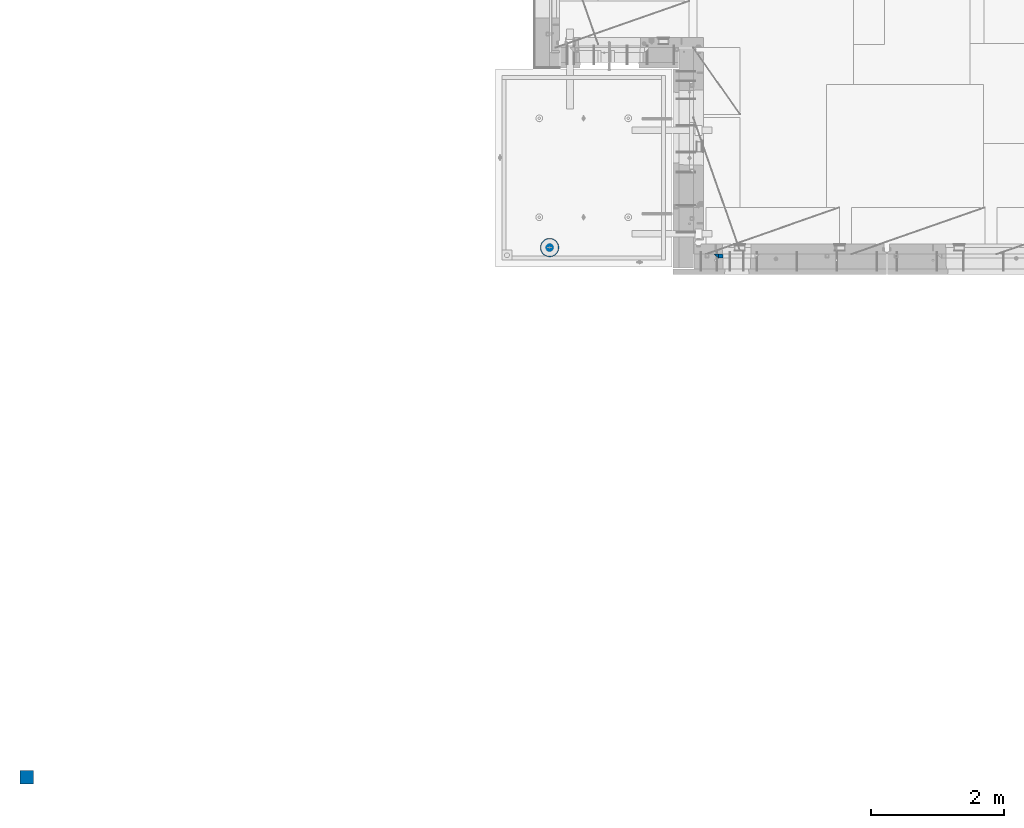
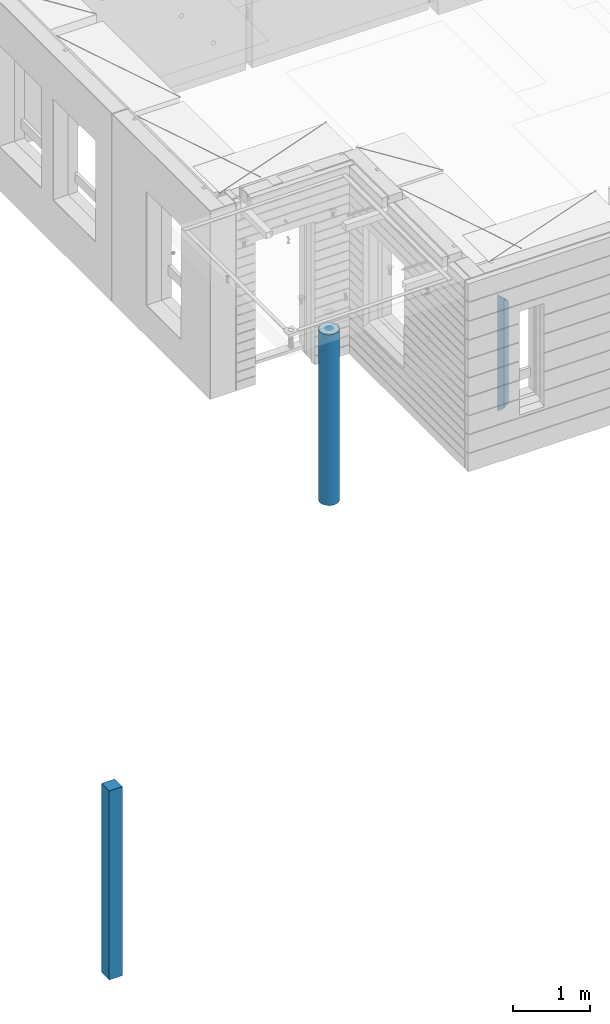
# One storey, part 1 of 352: 4 columns, 3 elements without a shape of their own.
"""IFC2X3 building model written with IfcOpenShell, lengths in millimetres."""

from ifc_helpers import new_model, si_unit, frame, origin_with_axes, place, context, subcontext, project, spatial, faceted_brep, material, type_object, element, aggregate, save


model = new_model("IFC2X3")

# Units and contexts
model_context = context("Model", 3, precision=1e-05, world=origin_with_axes())
body_context = subcontext(model_context, "Body", "Model", "MODEL_VIEW")
ifc_project = project(units=[si_unit("LENGTHUNIT", "METRE", prefix="MILLI"), si_unit("AREAUNIT", "SQUARE_METRE"), si_unit("VOLUMEUNIT", "CUBIC_METRE"), si_unit("MASSUNIT", "GRAM", prefix="KILO"), si_unit("TIMEUNIT", "SECOND"), si_unit("PLANEANGLEUNIT", "RADIAN"), si_unit("SOLIDANGLEUNIT", "STERADIAN"), si_unit("THERMODYNAMICTEMPERATUREUNIT", "DEGREE_CELSIUS"), si_unit("LUMINOUSINTENSITYUNIT", "LUMEN")], contexts=[model_context])

# Site, building, storey
site_placement = place(None, origin_with_axes())
site = spatial("IfcSite", under=ifc_project, at=site_placement, CompositionType="ELEMENT")
building_placement = place(site_placement, origin_with_axes())
building = spatial("IfcBuilding", under=site, at=building_placement, CompositionType="ELEMENT")
storey_placement = place(building_placement, origin_with_axes())
storey = spatial("IfcBuildingStorey", under=building, at=storey_placement, Name="6", CompositionType="ELEMENT", Elevation=0.0)

# Assembly, columns
assembly_1_placement = place(storey_placement, origin_with_axes())
assembly_1 = element("IfcElementAssembly", 1, at=assembly_1_placement, inside=storey, AssemblyPlace="NOTDEFINED", PredefinedType="REINFORCEMENT_UNIT")
ifc_material_1 = material(Name="CONCRETE/C25/30")
column_type_1 = type_object("IfcColumnType", PredefinedType="NOTDEFINED")
column_1_placement = place(assembly_1_placement, frame((10354.997879677, 7820.0, 97320.0), z_axis=(1.0, 0.0, 0.0), x_axis=(0.0, 0.0, 1.0)))
column_1 = element("IfcColumn", 2, at=column_1_placement, type_object=column_type_1, material=ifc_material_1, Name="SK", context=body_context, shape_type="Brep", body=[
    faceted_brep([(1795.00000000001, -30.0, 30.0), (1855.0, -30.0, -30.0), (1795.00000000001, 30.0, 30.0), (60.0000000000073, -30.0, 30.0), (0.0, -30.0, -30.0), (60.0000000000073, 30.0, 30.0)], [[[0, 1, 2]], [[1, 0, 3, 4]], [[2, 1, 4, 5]], [[0, 2, 5, 3]], [[5, 4, 3]]]),
])
column_type_2 = type_object("IfcColumnType", PredefinedType="NOTDEFINED")
column_2_placement = place(assembly_1_placement, frame((10419.997879677, 7820.0, 97380.0), z_axis=(1.0, 0.0, 0.0), x_axis=(0.0, 0.0, 1.0)))
column_2 = element("IfcColumn", 3, at=column_2_placement, type_object=column_type_2, material=ifc_material_1, Name="SK", context=body_context, shape_type="Brep", body=[
    faceted_brep([(1735.0, -30.0, -35.0), (1735.0, 30.0, -35.0), (1678.70525582272, 30.0, 30.6772015545812), (1680.09521721235, -30.0, 29.0555799329595), (56.2947441772849, 30.0, 30.6772015545812), (54.9047827876348, -30.0, 29.0555799329595), (0.0, -30.0, -35.0), (0.0, 30.0, -35.0)], [[[0, 1, 2, 3]], [[3, 2, 4, 5]], [[0, 3, 5, 6]], [[1, 0, 6, 7]], [[2, 1, 7, 4]], [[6, 5, 4, 7]]]),
])
aggregate(assembly_1, [column_1, column_2])

# Assembly, column
assembly_2_placement = place(storey_placement, origin_with_axes())
assembly_2 = element("IfcElementAssembly", 4, at=assembly_2_placement, inside=storey, AssemblyPlace="NOTDEFINED", PredefinedType="REINFORCEMENT_UNIT")
ifc_material_2 = material(Name="CONCRETE/Concrete_Undefined")
column_type_3 = type_object("IfcColumnType", PredefinedType="NOTDEFINED")
column_3_placement = place(assembly_2_placement, frame((0.0, 0.0, 96760.0), z_axis=(0.0, 1.0, 0.0), x_axis=(0.0, 0.0, 1.0)))
column_3 = element("IfcColumn", 5, at=column_3_placement, type_object=column_type_3, material=ifc_material_2, context=body_context, shape_type="Brep", body=[
    faceted_brep([(0.0, 100.0, -100.0), (0.0, 100.0, 100.0), (3000.0, 100.0, 100.0), (3000.0, 100.0, -100.0), (0.0, -100.0, 100.0), (3000.0, -100.0, 100.0), (0.0, -100.0, -100.0), (3000.0, -100.0, -100.0)], [[[0, 1, 2, 3]], [[1, 4, 5, 2]], [[4, 6, 7, 5]], [[6, 0, 3, 7]], [[5, 7, 3, 2]], [[6, 4, 1, 0]]]),
])
aggregate(assembly_2, [column_3])

assembly_3_placement = place(storey_placement, origin_with_axes())
assembly_3 = element("IfcElementAssembly", 6, at=assembly_3_placement, inside=storey, AssemblyPlace="NOTDEFINED", PredefinedType="REINFORCEMENT_UNIT")
ifc_material_3 = material(Name="CONCRETE/C30/37")
column_type_4 = type_object("IfcColumnType", Name="D280", PredefinedType="NOTDEFINED")
column_4_placement = place(assembly_3_placement, frame((7849.99879520436, 7949.98488883804, 96725.0), z_axis=(-1.0, 3.00000001838171e-08, 0.0), x_axis=(0.0, 0.0, 1.0)))
column_4 = element("IfcColumn", 7, at=column_4_placement, type_object=column_type_4, material=ifc_material_3, ObjectType="D280", context=body_context, shape_type="Brep", body=[
    faceted_brep([(0.0, -140.0, 0.0), (0.0, -136.489907705454, -31.1529307538876), (2710.0, -136.489907705454, -31.1529307538876), (2710.0, -140.0, 0.0), (0.0, -126.135641506338, -60.7437234764584), (2710.0, -126.135641506338, -60.7437234764584), (0.0, -109.456407545524, -87.2885722602223), (2710.0, -109.456407545524, -87.2885722602223), (0.0, -87.2885722602223, -109.456407545527), (2710.0, -87.2885722602223, -109.456407545527), (0.0, -60.7437234764584, -126.135641506342), (2710.0, -60.7437234764584, -126.135641506342), (0.0, -31.152930753884, -136.489907705458), (2710.0, -31.152930753884, -136.489907705458), (0.0, 0.0, -140.0), (2710.0, 0.0, -140.0), (0.0, 31.152930753884, -136.489907705458), (2710.0, 31.152930753884, -136.489907705458), (0.0, 60.7437234764584, -126.135641506342), (2710.0, 60.7437234764584, -126.135641506342), (0.0, 87.2885722602223, -109.456407545527), (2710.0, 87.2885722602223, -109.456407545527), (0.0, 109.456407545524, -87.2885722602223), (2710.0, 109.456407545524, -87.2885722602223), (0.0, 126.135641506338, -60.7437234764584), (2710.0, 126.135641506338, -60.7437234764584), (0.0, 136.489907705454, -31.1529307538876), (2710.0, 136.489907705454, -31.1529307538876), (0.0, 140.0, 0.0), (2710.0, 140.0, 0.0), (0.0, 136.489907705454, 31.1529307538876), (2710.0, 136.489907705454, 31.1529307538876), (0.0, 126.135641506338, 60.7437234764584), (2710.0, 126.135641506338, 60.7437234764584), (0.0, 109.456407545524, 87.2885722602223), (2710.0, 109.456407545524, 87.2885722602223), (0.0, 87.2885722602223, 109.456407545527), (2710.0, 87.2885722602223, 109.456407545527), (0.0, 60.7437234764584, 126.135641506342), (2710.0, 60.7437234764584, 126.135641506342), (0.0, 31.152930753884, 136.489907705458), (2710.0, 31.152930753884, 136.489907705458), (0.0, 0.0, 140.0), (2710.0, 0.0, 140.0), (0.0, -31.152930753884, 136.489907705458), (2710.0, -31.152930753884, 136.489907705458), (0.0, -60.7437234764584, 126.135641506342), (2710.0, -60.7437234764584, 126.135641506342), (0.0, -87.2885722602223, 109.456407545527), (2710.0, -87.2885722602223, 109.456407545527), (0.0, -109.456407545524, 87.2885722602223), (2710.0, -109.456407545524, 87.2885722602223), (0.0, -126.135641506338, 60.7437234764584), (2710.0, -126.135641506338, 60.7437234764584), (0.0, -136.489907705454, 31.1529307538876), (2710.0, -136.489907705454, 31.1529307538876)], [[[0, 1, 2, 3]], [[1, 4, 5, 2]], [[4, 6, 7, 5]], [[6, 8, 9, 7]], [[8, 10, 11, 9]], [[10, 12, 13, 11]], [[12, 14, 15, 13]], [[14, 16, 17, 15]], [[16, 18, 19, 17]], [[18, 20, 21, 19]], [[20, 22, 23, 21]], [[22, 24, 25, 23]], [[24, 26, 27, 25]], [[26, 28, 29, 27]], [[28, 30, 31, 29]], [[30, 32, 33, 31]], [[32, 34, 35, 33]], [[34, 36, 37, 35]], [[36, 38, 39, 37]], [[38, 40, 41, 39]], [[40, 42, 43, 41]], [[42, 44, 45, 43]], [[44, 46, 47, 45]], [[46, 48, 49, 47]], [[48, 50, 51, 49]], [[50, 52, 53, 51]], [[52, 54, 55, 53]], [[54, 0, 3, 55]], [[5, 7, 9, 11, 13, 15, 17, 19, 21, 23, 25, 27, 29, 31, 33, 35, 37, 39, 41, 43, 45, 47, 49, 51, 53, 55, 3, 2]], [[54, 52, 50, 48, 46, 44, 42, 40, 38, 36, 34, 32, 30, 28, 26, 24, 22, 20, 18, 16, 14, 12, 10, 8, 6, 4, 1, 0]]]),
])
aggregate(assembly_3, [column_4])

save(model, "model.ifc")
